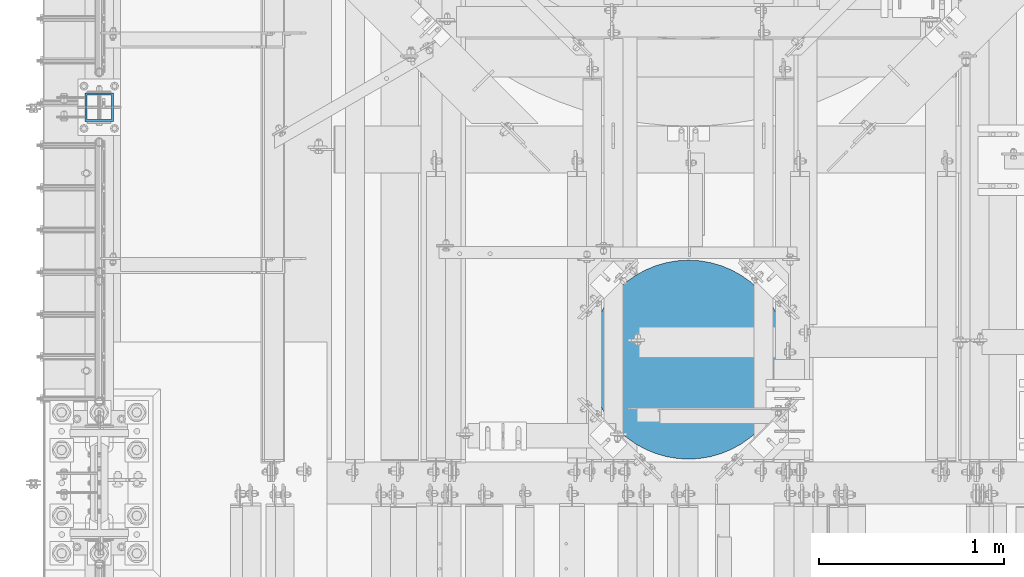
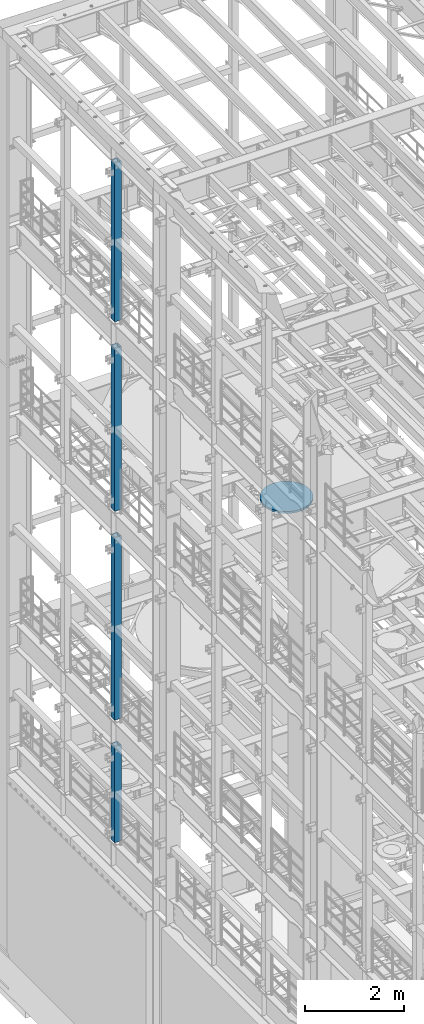
# One storey, part 737 of 1876: 5 columns, 5 elements without a shape of their own.
"""IFC2X3 building model written with IfcOpenShell, lengths in millimetres."""

from ifc_helpers import new_model, si_unit, frame, origin_with_axes, place, context, subcontext, project, spatial, faceted_brep, material, type_object, element, aggregate, save


model = new_model("IFC2X3")

# Units and contexts
model_context = context("Model", 3, precision=1e-05, world=origin_with_axes())
body_context = subcontext(model_context, "Body", "Model", "MODEL_VIEW")
ifc_project = project(units=[si_unit("LENGTHUNIT", "METRE", prefix="MILLI"), si_unit("AREAUNIT", "SQUARE_METRE"), si_unit("VOLUMEUNIT", "CUBIC_METRE"), si_unit("MASSUNIT", "GRAM", prefix="KILO"), si_unit("TIMEUNIT", "SECOND"), si_unit("PLANEANGLEUNIT", "RADIAN"), si_unit("SOLIDANGLEUNIT", "STERADIAN"), si_unit("THERMODYNAMICTEMPERATUREUNIT", "DEGREE_CELSIUS"), si_unit("LUMINOUSINTENSITYUNIT", "LUMEN")], contexts=[model_context])

# Site, building, storey
site_placement = place(None, origin_with_axes())
site = spatial("IfcSite", under=ifc_project, at=site_placement, CompositionType="ELEMENT")
building_placement = place(site_placement, origin_with_axes())
building = spatial("IfcBuilding", under=site, at=building_placement, Name="Undefined", CompositionType="ELEMENT")
storey_placement = place(building_placement, origin_with_axes())
storey = spatial("IfcBuildingStorey", under=building, at=storey_placement, Name="Undefined", CompositionType="ELEMENT", Elevation=0.0)

# Assembly, column
assembly_1_placement = place(storey_placement, origin_with_axes())
assembly_1 = element("IfcElementAssembly", 1, at=assembly_1_placement, inside=storey, Name="BEAM", AssemblyPlace="NOTDEFINED", PredefinedType="RIGID_FRAME")
ifc_material_1 = material()
column_type_1 = type_object("IfcColumnType", Name="HSS6X6X3/8", PredefinedType="NOTDEFINED")
column_1_placement = place(assembly_1_placement, frame((0.0, 9652.0, 17983.2), z_axis=(-1.0, 0.0, 0.0), x_axis=(0.0, 0.0, 1.0)))
column_1 = element("IfcColumn", 2, at=column_1_placement, type_object=column_type_1, material=ifc_material_1, Name="COLUMN", ObjectType="HSS6X6X3/8", context=body_context, shape_type="Brep", body=[
    faceted_brep([(12.7000000000016, 66.6750000000002, -66.6750000000002), (12.7000000000016, -66.6750000000002, -66.6750000000002), (3937.0, -66.6750000000002, -66.675), (3937.0, 66.6750000000002, -66.675), (12.7000000000016, -66.6750000000002, 66.6750000000002), (3937.0, -66.6750000000002, 66.675), (12.7000000000016, 66.6750000000002, 66.6750000000002), (3937.0, 66.6750000000002, 66.675), (12.7000000000016, 76.1999999999998, -76.1999999999998), (12.7000000000016, 76.1999999999998, 76.1999999999998), (3937.0, 76.1999999999998, 76.2), (3937.0, 76.1999999999998, -76.2), (12.7000000000016, -76.1999999999998, 76.1999999999998), (3937.0, -76.1999999999998, 76.2), (12.7000000000016, -76.1999999999998, -76.1999999999998), (3937.0, -76.1999999999998, -76.2)], [[[0, 1, 2, 3]], [[1, 4, 5, 2]], [[4, 6, 7, 5]], [[6, 0, 3, 7]], [[8, 9, 10, 11]], [[9, 12, 13, 10]], [[12, 14, 15, 13]], [[14, 8, 11, 15]], [[13, 15, 11, 10], [5, 7, 3, 2]], [[14, 12, 9, 8], [6, 4, 1, 0]]]),
])
aggregate(assembly_1, [column_1])

assembly_2_placement = place(storey_placement, origin_with_axes())
assembly_2 = element("IfcElementAssembly", 3, at=assembly_2_placement, inside=storey, Name="BEAM", AssemblyPlace="NOTDEFINED", PredefinedType="RIGID_FRAME")
column_2_placement = place(assembly_2_placement, frame((0.0, 9652.0, 13309.6), z_axis=(-1.0, 0.0, 0.0), x_axis=(0.0, 0.0, 1.0)))
column_2 = element("IfcColumn", 4, at=column_2_placement, type_object=column_type_1, material=ifc_material_1, Name="COLUMN", ObjectType="HSS6X6X3/8", context=body_context, shape_type="Brep", body=[
    faceted_brep([(12.7000000000016, 66.6750000000002, -66.6750000000002), (12.7000000000016, -66.6750000000002, -66.6750000000002), (4038.6, -66.6750000000002, -66.675), (4038.6, 66.6750000000002, -66.675), (12.7000000000016, -66.6750000000002, 66.6750000000002), (4038.6, -66.6750000000002, 66.675), (12.7000000000016, 66.6750000000002, 66.6750000000002), (4038.6, 66.6750000000002, 66.675), (12.7000000000016, 76.1999999999998, -76.1999999999998), (12.7000000000016, 76.1999999999998, 76.1999999999998), (4038.6, 76.1999999999998, 76.2), (4038.6, 76.1999999999998, -76.2), (12.7000000000016, -76.1999999999998, 76.1999999999998), (4038.6, -76.1999999999998, 76.2), (12.7000000000016, -76.1999999999998, -76.1999999999998), (4038.6, -76.1999999999998, -76.2)], [[[0, 1, 2, 3]], [[1, 4, 5, 2]], [[4, 6, 7, 5]], [[6, 0, 3, 7]], [[8, 9, 10, 11]], [[9, 12, 13, 10]], [[12, 14, 15, 13]], [[14, 8, 11, 15]], [[13, 15, 11, 10], [5, 7, 3, 2]], [[14, 12, 9, 8], [6, 4, 1, 0]]]),
])
aggregate(assembly_2, [column_2])

assembly_3_placement = place(storey_placement, origin_with_axes())
assembly_3 = element("IfcElementAssembly", 5, at=assembly_3_placement, inside=storey, Name="BEAM", AssemblyPlace="NOTDEFINED", PredefinedType="RIGID_FRAME")
column_3_placement = place(assembly_3_placement, frame((0.0, 9652.0, 8153.4), z_axis=(-0.999999999563517, 0.0, -2.95459999870218e-05), x_axis=(-2.95459999861759e-05, 0.0, 0.999999999563517)))
column_3 = element("IfcColumn", 6, at=column_3_placement, type_object=column_type_1, material=ifc_material_1, Name="COLUMN", ObjectType="HSS6X6X3/8", context=body_context, shape_type="Brep", body=[
    faceted_brep([(12.698030025992, 66.6750000000002, -66.675), (12.698030025992, -66.6750000000002, -66.675), (4521.2007045434, -66.6750000000002, -66.675), (4521.2007045434, 66.6750000000002, -66.675), (12.7019699850925, -66.6750000000002, 66.675), (4521.20070454334, -66.6750000000002, 66.675), (12.7019699850925, 66.6750000000002, 66.675), (4521.20070454334, 66.6750000000002, 66.675), (12.6977486003425, 76.1999999999998, -76.2), (12.7022514107421, 76.1999999999998, 76.2), (4521.20070454334, 76.1999999999998, 76.2), (4521.2007045434, 76.1999999999998, -76.2), (12.7022514107421, -76.1999999999998, 76.2), (4521.20070454334, -76.1999999999998, 76.2), (12.6977486003425, -76.1999999999998, -76.2), (4521.2007045434, -76.1999999999998, -76.2)], [[[0, 1, 2, 3]], [[1, 4, 5, 2]], [[4, 6, 7, 5]], [[6, 0, 3, 7]], [[8, 9, 10, 11]], [[9, 12, 13, 10]], [[12, 14, 15, 13]], [[14, 8, 11, 15]], [[13, 15, 11, 10], [5, 7, 3, 2]], [[14, 12, 9, 8], [6, 4, 1, 0]]]),
])
aggregate(assembly_3, [column_3])

assembly_4_placement = place(storey_placement, origin_with_axes())
assembly_4 = element("IfcElementAssembly", 7, at=assembly_4_placement, inside=storey, Name="BEAM", AssemblyPlace="NOTDEFINED", PredefinedType="RIGID_FRAME")
column_4_placement = place(assembly_4_placement, frame((0.0, 9652.0, 5130.8), z_axis=(-0.999999998434855, 0.0, -5.59490000241567e-05), x_axis=(-5.59490000243298e-05, 0.0, 0.999999998434855)))
column_4 = element("IfcColumn", 8, at=column_4_placement, type_object=column_type_1, material=ifc_material_1, Name="COLUMN", ObjectType="HSS6X6X3/8", context=body_context, shape_type="Brep", body=[
    faceted_brep([(12.6962696202891, 66.6750000000002, -66.675), (12.6962696202891, -66.6750000000002, -66.675), (2387.60070630699, -66.6750000000002, -66.675), (2387.60070630699, 66.6750000000002, -66.675), (12.7037304194646, -66.6750000000002, 66.675), (2387.600706307, -66.6750000000002, 66.675), (12.7037304194646, 66.6750000000002, 66.675), (2387.600706307, 66.6750000000002, 66.675), (12.6957367060613, 76.1999999999998, -76.2), (12.7042633336914, 76.1999999999998, 76.2), (2387.600706307, 76.1999999999998, 76.2), (2387.60070630699, 76.1999999999998, -76.2), (12.7042633336914, -76.1999999999998, 76.2), (2387.600706307, -76.1999999999998, 76.2), (12.6957367060613, -76.1999999999998, -76.2), (2387.60070630699, -76.1999999999998, -76.2)], [[[0, 1, 2, 3]], [[1, 4, 5, 2]], [[4, 6, 7, 5]], [[6, 0, 3, 7]], [[8, 9, 10, 11]], [[9, 12, 13, 10]], [[12, 14, 15, 13]], [[14, 8, 11, 15]], [[13, 15, 11, 10], [5, 7, 3, 2]], [[14, 12, 9, 8], [6, 4, 1, 0]]]),
])
aggregate(assembly_4, [column_4])

assembly_5_placement = place(storey_placement, origin_with_axes())
assembly_5 = element("IfcElementAssembly", 9, at=assembly_5_placement, inside=storey, Name="COLUMN", AssemblyPlace="NOTDEFINED", PredefinedType="REINFORCEMENT_UNIT")
ifc_material_2 = material(Name="CONCRETE/3000")
column_type_2 = type_object("IfcColumnType", PredefinedType="NOTDEFINED")
column_5_placement = place(assembly_5_placement, frame((3187.7, 8286.75, 13284.2), z_axis=(-1.0, 0.0, 0.0), x_axis=(0.0, 0.0, 1.0)))
column_5 = element("IfcColumn", 10, at=column_5_placement, type_object=column_type_2, material=ifc_material_2, Name="COLUMN", context=body_context, shape_type="Brep", body=[
    faceted_brep([(0.0, -538.1625, 0.0), (0.0, -534.778647156672, -60.2550823709462), (50.7999999999993, -534.778647156672, -60.2550823709462), (50.7999999999993, -538.1625, 0.0), (0.0, -524.669642539551, -119.752422120265), (50.7999999999993, -524.669642539551, -119.752422120265), (0.0, -507.962612747077, -177.743805679448), (50.7999999999993, -507.962612747077, -177.743805679448), (0.0, -484.867658372536, -233.499957752853), (50.7999999999993, -484.867658372536, -233.499957752853), (0.0, -455.675211867192, -286.319712377684), (50.7999999999993, -455.675211867192, -286.319712377684), (0.0, -420.752385183701, -335.538830492801), (50.7999999999993, -420.752385183701, -335.538830492801), (0.0, -380.538353130305, -380.538353130305), (50.7999999999993, -380.538353130305, -380.538353130305), (0.0, -335.538830492801, -420.752385183701), (50.7999999999993, -335.538830492801, -420.752385183701), (0.0, -286.319712377684, -455.675211867191), (50.7999999999993, -286.319712377684, -455.675211867191), (0.0, -233.499957752853, -484.867658372536), (50.7999999999993, -233.499957752853, -484.867658372536), (0.0, -177.743805679448, -507.962612747076), (50.7999999999993, -177.743805679448, -507.962612747076), (0.0, -119.752422120265, -524.66964253955), (50.7999999999993, -119.752422120265, -524.66964253955), (0.0, -60.2550823709462, -534.778647156672), (50.7999999999993, -60.2550823709462, -534.778647156672), (0.0, 0.0, -538.1625), (50.7999999999993, 0.0, -538.1625), (0.0, 60.2550823709466, -534.778647156672), (50.7999999999993, 60.2550823709466, -534.778647156672), (0.0, 119.752422120265, -524.66964253955), (50.7999999999993, 119.752422120265, -524.66964253955), (0.0, 177.743805679448, -507.962612747076), (50.7999999999993, 177.743805679448, -507.962612747076), (0.0, 233.499957752853, -484.867658372536), (50.7999999999993, 233.499957752853, -484.867658372536), (0.0, 286.319712377685, -455.675211867191), (50.7999999999993, 286.319712377685, -455.675211867191), (0.0, 335.538830492801, -420.752385183701), (50.7999999999993, 335.538830492801, -420.752385183701), (0.0, 380.538353130305, -380.538353130305), (50.7999999999993, 380.538353130305, -380.538353130305), (0.0, 420.752385183701, -335.538830492801), (50.7999999999993, 420.752385183701, -335.538830492801), (0.0, 455.675211867191, -286.319712377684), (50.7999999999993, 455.675211867191, -286.319712377684), (0.0, 484.867658372536, -233.499957752852), (50.7999999999993, 484.867658372536, -233.499957752852), (0.0, 507.962612747076, -177.743805679447), (50.7999999999993, 507.962612747076, -177.743805679447), (0.0, 524.66964253955, -119.752422120265), (50.7999999999993, 524.66964253955, -119.752422120265), (0.0, 534.778647156672, -60.2550823709462), (50.7999999999993, 534.778647156672, -60.2550823709462), (0.0, 538.1625, 0.0), (50.7999999999993, 538.1625, 0.0), (0.0, 534.778647156672, 60.2550823709462), (50.7999999999993, 534.778647156672, 60.2550823709462), (0.0, 524.66964253955, 119.752422120265), (50.7999999999993, 524.66964253955, 119.752422120265), (0.0, 507.962612747076, 177.743805679448), (50.7999999999993, 507.962612747076, 177.743805679448), (0.0, 484.867658372536, 233.499957752853), (50.7999999999993, 484.867658372536, 233.499957752853), (0.0, 455.675211867191, 286.319712377684), (50.7999999999993, 455.675211867191, 286.319712377684), (0.0, 420.752385183701, 335.538830492801), (50.7999999999993, 420.752385183701, 335.538830492801), (0.0, 380.538353130305, 380.538353130305), (50.7999999999993, 380.538353130305, 380.538353130305), (0.0, 335.538830492801, 420.752385183701), (50.7999999999993, 335.538830492801, 420.752385183701), (0.0, 286.319712377685, 455.675211867191), (50.7999999999993, 286.319712377685, 455.675211867191), (0.0, 233.499957752853, 484.867658372536), (50.7999999999993, 233.499957752853, 484.867658372536), (0.0, 177.743805679448, 507.962612747076), (50.7999999999993, 177.743805679448, 507.962612747076), (0.0, 119.752422120265, 524.66964253955), (50.7999999999993, 119.752422120265, 524.66964253955), (0.0, 60.2550823709462, 534.778647156672), (50.7999999999993, 60.2550823709462, 534.778647156672), (0.0, 0.0, 538.1625), (50.7999999999993, 0.0, 538.1625), (0.0, -60.2550823709466, 534.778647156672), (50.7999999999993, -60.2550823709466, 534.778647156672), (0.0, -119.752422120265, 524.66964253955), (50.7999999999993, -119.752422120265, 524.66964253955), (0.0, -177.743805679448, 507.962612747076), (50.7999999999993, -177.743805679448, 507.962612747076), (0.0, -233.499957752853, 484.867658372536), (50.7999999999993, -233.499957752853, 484.867658372536), (0.0, -286.319712377685, 455.675211867191), (50.7999999999993, -286.319712377685, 455.675211867191), (0.0, -335.538830492801, 420.752385183701), (50.7999999999993, -335.538830492801, 420.752385183701), (0.0, -380.538353130305, 380.538353130305), (50.7999999999993, -380.538353130305, 380.538353130305), (0.0, -420.752385183701, 335.538830492801), (50.7999999999993, -420.752385183701, 335.538830492801), (0.0, -455.675211867192, 286.319712377684), (50.7999999999993, -455.675211867192, 286.319712377684), (0.0, -484.867658372536, 233.499957752852), (50.7999999999993, -484.867658372536, 233.499957752852), (0.0, -507.962612747077, 177.743805679447), (50.7999999999993, -507.962612747077, 177.743805679447), (0.0, -524.669642539551, 119.752422120265), (50.7999999999993, -524.669642539551, 119.752422120265), (0.0, -534.778647156672, 60.2550823709462), (50.7999999999993, -534.778647156672, 60.2550823709462)], [[[0, 1, 2, 3]], [[1, 4, 5, 2]], [[4, 6, 7, 5]], [[6, 8, 9, 7]], [[8, 10, 11, 9]], [[10, 12, 13, 11]], [[12, 14, 15, 13]], [[14, 16, 17, 15]], [[16, 18, 19, 17]], [[18, 20, 21, 19]], [[20, 22, 23, 21]], [[22, 24, 25, 23]], [[24, 26, 27, 25]], [[26, 28, 29, 27]], [[28, 30, 31, 29]], [[30, 32, 33, 31]], [[32, 34, 35, 33]], [[34, 36, 37, 35]], [[36, 38, 39, 37]], [[38, 40, 41, 39]], [[40, 42, 43, 41]], [[42, 44, 45, 43]], [[44, 46, 47, 45]], [[46, 48, 49, 47]], [[48, 50, 51, 49]], [[50, 52, 53, 51]], [[52, 54, 55, 53]], [[54, 56, 57, 55]], [[56, 58, 59, 57]], [[58, 60, 61, 59]], [[60, 62, 63, 61]], [[62, 64, 65, 63]], [[64, 66, 67, 65]], [[66, 68, 69, 67]], [[68, 70, 71, 69]], [[70, 72, 73, 71]], [[72, 74, 75, 73]], [[74, 76, 77, 75]], [[76, 78, 79, 77]], [[78, 80, 81, 79]], [[80, 82, 83, 81]], [[82, 84, 85, 83]], [[84, 86, 87, 85]], [[86, 88, 89, 87]], [[88, 90, 91, 89]], [[90, 92, 93, 91]], [[92, 94, 95, 93]], [[94, 96, 97, 95]], [[96, 98, 99, 97]], [[98, 100, 101, 99]], [[100, 102, 103, 101]], [[102, 104, 105, 103]], [[104, 106, 107, 105]], [[106, 108, 109, 107]], [[108, 110, 111, 109]], [[110, 0, 3, 111]], [[5, 7, 9, 11, 13, 15, 17, 19, 21, 23, 25, 27, 29, 31, 33, 35, 37, 39, 41, 43, 45, 47, 49, 51, 53, 55, 57, 59, 61, 63, 65, 67, 69, 71, 73, 75, 77, 79, 81, 83, 85, 87, 89, 91, 93, 95, 97, 99, 101, 103, 105, 107, 109, 111, 3, 2]], [[110, 108, 106, 104, 102, 100, 98, 96, 94, 92, 90, 88, 86, 84, 82, 80, 78, 76, 74, 72, 70, 68, 66, 64, 62, 60, 58, 56, 54, 52, 50, 48, 46, 44, 42, 40, 38, 36, 34, 32, 30, 28, 26, 24, 22, 20, 18, 16, 14, 12, 10, 8, 6, 4, 1, 0]]]),
])
aggregate(assembly_5, [column_5])

save(model, "model.ifc")
